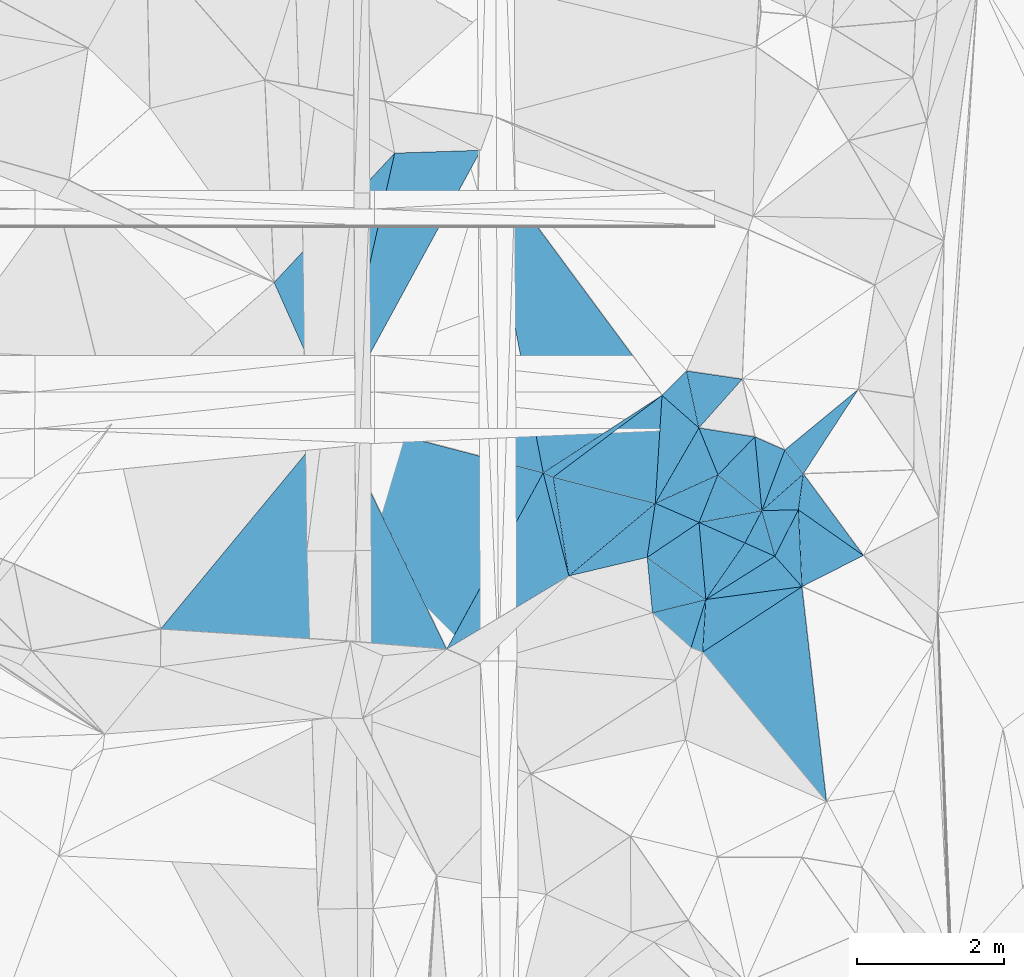
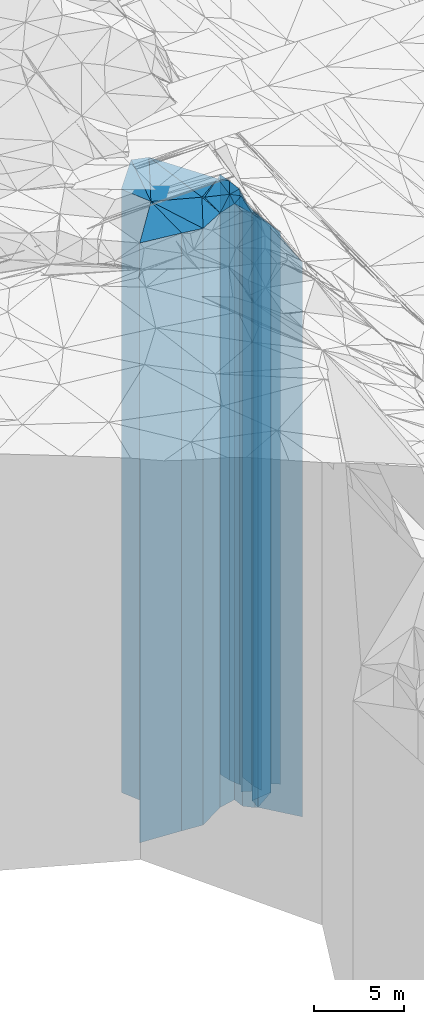
# One storey, part 210 of 275: 41 plates.
"""IFC2X3 building model written with IfcOpenShell, lengths in millimetres."""

from ifc_helpers import new_model, si_unit, frame, origin_with_axes, place, context, subcontext, project, spatial, faceted_brep, material, type_object, element, save


model = new_model("IFC2X3")

# Units and contexts
model_context = context("Model", 3, precision=1e-05, world=origin_with_axes())
body_context = subcontext(model_context, "Body", "Model", "MODEL_VIEW")
ifc_project = project(units=[si_unit("LENGTHUNIT", "METRE", prefix="MILLI"), si_unit("AREAUNIT", "SQUARE_METRE"), si_unit("VOLUMEUNIT", "CUBIC_METRE"), si_unit("MASSUNIT", "GRAM", prefix="KILO"), si_unit("TIMEUNIT", "SECOND"), si_unit("PLANEANGLEUNIT", "RADIAN"), si_unit("SOLIDANGLEUNIT", "STERADIAN"), si_unit("THERMODYNAMICTEMPERATUREUNIT", "DEGREE_CELSIUS"), si_unit("LUMINOUSINTENSITYUNIT", "LUMEN")], contexts=[model_context])

# Site, building, storey
site_placement = place(None, origin_with_axes())
site = spatial("IfcSite", under=ifc_project, at=site_placement, CompositionType="ELEMENT")
building_placement = place(site_placement, origin_with_axes())
building = spatial("IfcBuilding", under=site, at=building_placement, Name="Undefined", CompositionType="ELEMENT")
storey_placement = place(building_placement, origin_with_axes())
storey = spatial("IfcBuildingStorey", under=building, at=storey_placement, Name="Undefined", CompositionType="ELEMENT", Elevation=0.0)

# Plates
ifc_material = material()
plate_type_1 = type_object("IfcPlateType", PredefinedType="NOTDEFINED")
plate_1_placement = place(storey_placement, frame((-106841.743380967, 59287.7253005679, 28269.0), z_axis=(0.912580697493601, 0.408896650221169, 0.0), x_axis=(0.408896650221169, -0.912580697493601, 0.0)))
element("IfcPlate", 1, at=plate_1_placement, inside=storey, type_object=plate_type_1, material=ifc_material, Name="00", context=body_context, shape_type="Brep", body=[
    faceted_brep([(0.0, -20441.0, 0.0), (-939.052673339844, -20791.0, 2224.65283203125), (-939.052673339844, 20441.0, 2224.65283203125), (2.91038304567337e-11, 20441.0, -1.45519152283669e-11), (2030.02465820313, -20441.0, -2.77941580861807e-09), (2030.02465820313, 20441.0, -2.77941580861807e-09)], [[[0, 1, 2, 3]], [[1, 4, 5, 2]], [[4, 0, 3, 5]], [[5, 3, 2]], [[4, 1, 0]]]),
])
plate_type_2 = type_object("IfcPlateType", PredefinedType="NOTDEFINED")
plate_2_placement = place(storey_placement, frame((-105195.543648921, 61054.3397016786, 28269.0), z_axis=(0.975504880489168, -0.219977790110307, 0.0), x_axis=(-0.219977790110309, -0.975504880489168, 0.0)))
element("IfcPlate", 2, at=plate_2_placement, inside=storey, type_object=plate_type_2, material=ifc_material, Name="00", context=body_context, shape_type="Brep", body=[
    faceted_brep([(-2.91038304567337e-11, -20791.0, -8.86757334228605e-12), (-295.871704101563, -20531.0, 1137.6114501953), (-295.871704101563, 20441.0, 1137.6114501953), (2.91038304567337e-11, 20441.0, -1.45519152283669e-11), (3710.05395507813, -20441.0, -5.07861841470003e-09), (3710.05395507813, 20441.0, -5.07861841470003e-09)], [[[0, 1, 2, 3]], [[1, 4, 5, 2]], [[4, 0, 3, 5]], [[5, 3, 2]], [[4, 1, 0]]]),
])
plate_type_3 = type_object("IfcPlateType", PredefinedType="NOTDEFINED")
plate_3_placement = place(storey_placement, frame((-100452.641159948, 57968.796640872, 27609.0), z_axis=(-0.145895997045634, -0.989299933309439, 0.0), x_axis=(-0.989299933309439, 0.145895997045634, 0.0)))
element("IfcPlate", 3, at=plate_3_placement, inside=storey, type_object=plate_type_3, material=ifc_material, Name="00", context=body_context, shape_type="Brep", body=[
    faceted_brep([(1.45519152283669e-11, -19781.0, -7.27595761418343e-12), (487.70010375978, -20821.0, 745.082946777344), (487.70010375978, 19781.0, 745.082946777344), (0.0, 19781.0, 0.0), (768.505065917983, -20881.0, 2.48110154643655e-09), (768.505065917954, 19781.0, 2.48837750405073e-09)], [[[0, 1, 2, 3]], [[1, 4, 5, 2]], [[4, 0, 3, 5]], [[5, 3, 2]], [[4, 1, 0]]]),
])
plate_type_4 = type_object("IfcPlateType", PredefinedType="NOTDEFINED")
plate_4_placement = place(storey_placement, frame((-101638.750597907, 56274.4104979918, 28099.0), z_axis=(-0.865602585242508, 0.500731629140287, 0.0), x_axis=(0.500731629140283, 0.865602585242511, 0.0)))
element("IfcPlate", 4, at=plate_4_placement, inside=storey, type_object=plate_type_4, material=ifc_material, Name="00", context=body_context, shape_type="Brep", body=[
    faceted_brep([(-5.45696821063757e-12, -20271.0, 0.0), (1321.26062011717, -20411.0, 657.852783203125), (1321.26062011717, 20271.0, 657.852783203125), (-5.45696821063757e-12, 20271.0, 0.0), (1188.10778808592, -20331.0, -6.34463503956795e-09), (1188.10778808592, 20271.0, -6.34463503956795e-09)], [[[0, 1, 2, 3]], [[1, 4, 5, 2]], [[4, 0, 3, 5]], [[5, 3, 2]], [[4, 1, 0]]]),
])
plate_type_5 = type_object("IfcPlateType", PredefinedType="NOTDEFINED")
plate_5_placement = place(storey_placement, frame((-103168.085030163, 56691.5869526421, 28144.0), z_axis=(-0.545695816690895, 0.83798333852533, 0.0), x_axis=(0.83798333852533, 0.545695816690894, 0.0)))
element("IfcPlate", 5, at=plate_5_placement, inside=storey, type_object=plate_type_5, material=ifc_material, Name="00", context=body_context, shape_type="Brep", body=[
    faceted_brep([(-1.45519152283669e-11, -20316.0, 0.0), (1687.18908691407, -20656.0, 4153.34716796876), (1687.18908691407, 20316.0, 4153.34716796876), (0.0, 20316.0, 0.0), (1934.99353027344, -20366.0, 2.02271621674299e-09), (1934.99353027344, 20316.0, 2.02271621674299e-09)], [[[0, 1, 2, 3]], [[1, 4, 5, 2]], [[4, 0, 3, 5]], [[5, 3, 2]], [[4, 1, 0]]]),
])
plate_type_6 = type_object("IfcPlateType", PredefinedType="NOTDEFINED")
plate_6_placement = place(storey_placement, frame((-100183.947940648, 56174.1646580124, 27079.0), z_axis=(-0.935515923827576, 0.353284525934887, 0.0), x_axis=(0.353284525934885, 0.935515923827576, 0.0)))
element("IfcPlate", 6, at=plate_6_placement, inside=storey, type_object=plate_type_6, material=ifc_material, Name="00", context=body_context, shape_type="Brep", body=[
    faceted_brep([(0.0, -19491.0, 1.45519152283669e-11), (908.687988281257, -19921.0, 445.293304443374), (908.687988281257, 19251.0, 445.293304443374), (0.0, 19251.0, 1.45519152283669e-11), (883.911743164055, -19251.0, -1.33877620100975e-09), (883.911743164055, 19251.0, -1.33877620100975e-09)], [[[0, 1, 2, 3]], [[1, 4, 5, 2]], [[4, 0, 3, 5]], [[5, 3, 2]], [[4, 1, 0]]]),
])
plate_type_7 = type_object("IfcPlateType", PredefinedType="NOTDEFINED")
plate_7_placement = place(storey_placement, frame((-100183.947940648, 56174.1646580124, 26949.0), z_axis=(-0.663522728184493, 0.748156126208031, 0.0), x_axis=(0.748156126208028, 0.663522728184497, 0.0)))
element("IfcPlate", 7, at=plate_7_placement, inside=storey, type_object=plate_type_7, material=ifc_material, Name="00", context=body_context, shape_type="Brep", body=[
    faceted_brep([(0.0, -19621.0, 0.0), (782.304382324211, -19381.0, 411.460632324219), (782.304382324211, 19121.0, 411.460632324219), (0.0, 19121.0, 0.0), (755.843872070298, -19121.0, -3.60887497663498e-09), (755.843872070298, 19121.0, -3.60887497663498e-09)], [[[0, 1, 2, 3]], [[1, 4, 5, 2]], [[4, 0, 3, 5]], [[5, 3, 2]], [[4, 1, 0]]]),
])
plate_type_8 = type_object("IfcPlateType", PredefinedType="NOTDEFINED")
plate_8_placement = place(storey_placement, frame((-100183.947940648, 56174.1646580124, 26949.0), z_axis=(-0.0246161959885678, 0.999696975535613, 0.0), x_axis=(0.999696975535613, 0.0246161959885656, 0.0)))
element("IfcPlate", 8, at=plate_8_placement, inside=storey, type_object=plate_type_8, material=ifc_material, Name="00", context=body_context, shape_type="Brep", body=[
    faceted_brep([(0.0, -19621.0, 0.0), (577.663391113267, -19121.0, 487.447448730469), (577.663391113267, 19121.0, 487.447448730469), (0.0, 19121.0, 0.0), (497.694671630845, -19191.0, -1.30967237055302e-09), (497.694671630845, 19121.0, -1.30967237055302e-09)], [[[0, 1, 2, 3]], [[1, 4, 5, 2]], [[4, 0, 3, 5]], [[5, 3, 2]], [[4, 1, 0]]]),
])
plate_type_9 = type_object("IfcPlateType", PredefinedType="NOTDEFINED")
plate_9_placement = place(storey_placement, frame((-98869.9844511925, 57826.6778798589, 26484.0), z_axis=(0.636018240790832, -0.771674022746221, 0.0), x_axis=(-0.77167402274622, -0.636018240790834, 0.0)))
element("IfcPlate", 9, at=plate_9_placement, inside=storey, type_object=plate_type_9, material=ifc_material, Name="00", context=body_context, shape_type="Brep", body=[
    faceted_brep([(2.91038304567337e-11, -18656.0, 0.0), (1309.63110351564, -19586.0, 412.148590087876), (1309.63110351564, 18656.0, 412.148590087876), (0.0, 18656.0, 7.27595761418343e-12), (1298.07543945314, -19846.0, 5.0931703299284e-10), (1298.07543945314, 18656.0, 5.0931703299284e-10)], [[[0, 1, 2, 3]], [[1, 4, 5, 2]], [[4, 0, 3, 5]], [[5, 3, 2]], [[4, 1, 0]]]),
])
plate_type_10 = type_object("IfcPlateType", PredefinedType="NOTDEFINED")
plate_10_placement = place(storey_placement, frame((-101638.750597907, 56274.4104979918, 28009.0), z_axis=(-0.414102456121684, 0.910230276267489, 0.0), x_axis=(0.910230276267486, 0.414102456121689, 0.0)))
element("IfcPlate", 10, at=plate_10_placement, inside=storey, type_object=plate_type_10, material=ifc_material, Name="00", context=body_context, shape_type="Brep", body=[
    faceted_brep([(0.0, -20361.0, 1.45519152283669e-11), (967.39208984375, -20421.0, 689.748229980469), (967.39208984375, 20181.0, 689.748229980469), (2.91038304567337e-11, 20181.0, 0.0), (940.053161621108, -20181.0, 4.38012648373842e-09), (940.053161621108, 20181.0, 4.38012648373842e-09)], [[[0, 1, 2, 3]], [[1, 4, 5, 2]], [[4, 0, 3, 5]], [[5, 3, 2]], [[4, 1, 0]]]),
])
plate_type_11 = type_object("IfcPlateType", PredefinedType="NOTDEFINED")
plate_11_placement = place(storey_placement, frame((-101212.923146997, 58080.9184503828, 28129.0), z_axis=(0.706835456151179, -0.707378002151293, 0.0), x_axis=(-0.707378002151296, -0.706835456151176, 0.0)))
element("IfcPlate", 11, at=plate_11_placement, inside=storey, type_object=plate_type_11, material=ifc_material, Name="00", context=body_context, shape_type="Brep", body=[
    faceted_brep([(0.0, -20361.0, 1.45519152283669e-11), (430.359130859364, -20301.0, 669.918640136704), (430.359130859364, 20301.0, 669.918640136704), (-1.09139364212751e-11, 20301.0, -1.45519152283669e-11), (471.699066162098, -20381.0, 1.46974343806505e-09), (471.699066162098, 20301.0, 1.46974343806505e-09)], [[[0, 1, 2, 3]], [[1, 4, 5, 2]], [[4, 0, 3, 5]], [[5, 3, 2]], [[4, 1, 0]]]),
])
plate_type_12 = type_object("IfcPlateType", PredefinedType="NOTDEFINED")
plate_12_placement = place(storey_placement, frame((-101042.223484436, 56013.3446003834, 27199.0), z_axis=(-0.184170593919691, 0.982894293571424, 0.0), x_axis=(0.982894293571423, 0.184170593919695, 0.0)))
element("IfcPlate", 12, at=plate_12_placement, inside=storey, type_object=plate_type_12, material=ifc_material, Name="00", context=body_context, shape_type="Brep", body=[
    faceted_brep([(1.45519152283669e-11, -21011.0, 1.45519152283669e-11), (374.479309082031, -20991.0, 591.494079589858), (374.479309082031, 19371.0, 591.494079589858), (1.45519152283669e-11, 19371.0, 1.45519152283669e-11), (873.212463378921, -19371.0, 2.83762346953154e-09), (873.212463378921, 19371.0, 2.83762346953154e-09)], [[[0, 1, 2, 3]], [[1, 4, 5, 2]], [[4, 0, 3, 5]], [[5, 3, 2]], [[4, 1, 0]]]),
])
plate_type_13 = type_object("IfcPlateType", PredefinedType="NOTDEFINED")
plate_13_placement = place(storey_placement, frame((-100279.501523875, 57181.5719801679, 27414.0), z_axis=(-0.156699567990614, -0.987646315940861, 0.0), x_axis=(-0.987646315940861, 0.156699567990614, 0.0)))
element("IfcPlate", 13, at=plate_13_placement, inside=storey, type_object=plate_type_13, material=ifc_material, Name="00", context=body_context, shape_type="Brep", body=[
    faceted_brep([(1.45519152283669e-11, -19586.0, -1.45519152283669e-11), (416.210998535171, -20776.0, 590.396789550781), (416.210998535171, 19586.0, 590.396789550781), (-7.27595761418343e-12, 19586.0, 0.0), (773.886291503921, -21016.0, 1.16415321826935e-09), (773.886291503921, 19586.0, 1.16415321826935e-09)], [[[0, 1, 2, 3]], [[1, 4, 5, 2]], [[4, 0, 3, 5]], [[5, 3, 2]], [[4, 1, 0]]]),
])
plate_type_14 = type_object("IfcPlateType", PredefinedType="NOTDEFINED")
plate_14_placement = place(storey_placement, frame((-99637.6375923021, 55136.4532321864, 26529.0), z_axis=(-0.452404799933225, 0.891812702868365, 0.0), x_axis=(0.891812702868366, 0.452404799933223, 0.0)))
element("IfcPlate", 14, at=plate_14_placement, inside=storey, type_object=plate_type_14, material=ifc_material, Name="00", context=body_context, shape_type="Brep", body=[
    faceted_brep([(-1.45519152283669e-11, -19731.0, 0.0), (431.517639160164, -19611.0, 958.432312011719), (431.517639160164, 18701.0, 958.432312011719), (-1.45519152283669e-11, 18701.0, 0.0), (941.328857421853, -18701.0, 1.12049747258425e-09), (941.328857421853, 18701.0, 1.12049747258425e-09)], [[[0, 1, 2, 3]], [[1, 4, 5, 2]], [[4, 0, 3, 5]], [[5, 3, 2]], [[4, 1, 0]]]),
])
plate_type_15 = type_object("IfcPlateType", PredefinedType="NOTDEFINED")
plate_15_placement = place(storey_placement, frame((-99618.4586970826, 56675.6842642209, 26529.0), z_axis=(0.990494632365923, -0.137551384050815, 0.0), x_axis=(-0.137551384050824, -0.990494632365922, 0.0)))
element("IfcPlate", 15, at=plate_15_placement, inside=storey, type_object=plate_type_15, material=ifc_material, Name="00", context=body_context, shape_type="Brep", body=[
    faceted_brep([(-7.27595761418343e-12, -19541.0, 0.0), (989.951538085945, -18701.0, 965.658264160156), (989.951538085945, 18701.0, 965.658264160156), (-1.45519152283669e-11, 18701.0, 0.0), (493.963562011719, -19611.0, -5.23868948221207e-10), (493.963562011719, 18701.0, -5.23868948221207e-10)], [[[0, 1, 2, 3]], [[1, 4, 5, 2]], [[4, 0, 3, 5]], [[5, 3, 2]], [[4, 1, 0]]]),
])
plate_type_16 = type_object("IfcPlateType", PredefinedType="NOTDEFINED")
plate_16_placement = place(storey_placement, frame((-101042.223484436, 56013.3446003834, 27199.0), z_axis=(0.40829029704525, 0.912852142101174, 0.0), x_axis=(0.912852142101172, -0.408290297045255, 0.0)))
element("IfcPlate", 16, at=plate_16_placement, inside=storey, type_object=plate_type_16, material=ifc_material, Name="00", context=body_context, shape_type="Brep", body=[
    faceted_brep([(1.45519152283669e-11, -21011.0, 1.45519152283669e-11), (717.817382812485, -19371.0, 497.230499267573), (717.817382812485, 19371.0, 497.230499267573), (1.45519152283669e-11, 19371.0, 1.45519152283669e-11), (686.804199218735, -19911.0, -2.42107489611954e-09), (686.804199218735, 19371.0, -2.42107489611954e-09)], [[[0, 1, 2, 3]], [[1, 4, 5, 2]], [[4, 0, 3, 5]], [[5, 3, 2]], [[4, 1, 0]]]),
])
plate_type_17 = type_object("IfcPlateType", PredefinedType="NOTDEFINED")
plate_17_placement = place(storey_placement, frame((-100183.947940648, 56174.1646580124, 27144.0), z_axis=(0.885665246512403, -0.464324316744369, 0.0), x_axis=(-0.464324316744365, -0.885665246512405, 0.0)))
element("IfcPlate", 17, at=plate_17_placement, inside=storey, type_object=plate_type_17, material=ifc_material, Name="00", context=body_context, shape_type="Brep", body=[
    faceted_brep([(7.27595761418343e-12, -19426.0, 0.0), (468.690338134773, -19316.0, 445.004913330078), (468.690338134773, 19316.0, 445.004913330078), (7.27595761418343e-12, 19316.0, 0.0), (498.196746826172, -19966.0, -1.33877620100975e-09), (498.196746826172, 19316.0, -1.33877620100975e-09)], [[[0, 1, 2, 3]], [[1, 4, 5, 2]], [[4, 0, 3, 5]], [[5, 3, 2]], [[4, 1, 0]]]),
])
plate_type_18 = type_object("IfcPlateType", PredefinedType="NOTDEFINED")
plate_18_placement = place(storey_placement, frame((-101749.814494169, 55536.464151062, 28019.0), z_axis=(-0.558874123941729, 0.829252502913537, 0.0), x_axis=(0.829252502913538, 0.558874123941726, 0.0)))
element("IfcPlate", 18, at=plate_18_placement, inside=storey, type_object=plate_type_18, material=ifc_material, Name="00", context=body_context, shape_type="Brep", body=[
    faceted_brep([(-7.27595761418343e-12, -20201.0, 0.0), (504.519134521477, -20351.0, 549.873107910171), (504.519134521477, 20191.0, 549.873107910171), (0.0, 20191.0, 0.0), (853.287780761711, -20191.0, 8.87666828930378e-10), (853.287780761711, 20191.0, 8.87666828930378e-10)], [[[0, 1, 2, 3]], [[1, 4, 5, 2]], [[4, 0, 3, 5]], [[5, 3, 2]], [[4, 1, 0]]]),
])
plate_type_19 = type_object("IfcPlateType", PredefinedType="NOTDEFINED")
plate_19_placement = place(storey_placement, frame((-101546.592683376, 57747.5048326457, 28099.0), z_axis=(0.600661016016313, -0.799503811021718, 0.0), x_axis=(-0.799503811021718, -0.600661016016313, 0.0)))
element("IfcPlate", 19, at=plate_19_placement, inside=storey, type_object=plate_type_19, material=ifc_material, Name="00", context=body_context, shape_type="Brep", body=[
    faceted_brep([(7.27595761418343e-12, -20411.0, 2.91038304567337e-11), (958.510925292961, -20271.0, 1122.38891601564), (958.510925292961, 20271.0, 1122.38891601564), (-5.45696821063757e-12, 20271.0, 0.0), (1858.09045410158, -20351.0, 3.88536136597395e-09), (1858.09045410158, 20271.0, 3.88536136597395e-09)], [[[0, 1, 2, 3]], [[1, 4, 5, 2]], [[4, 0, 3, 5]], [[5, 3, 2]], [[4, 1, 0]]]),
])
plate_type_20 = type_object("IfcPlateType", PredefinedType="NOTDEFINED")
plate_20_placement = place(storey_placement, frame((-100948.785727706, 54961.2659979884, 27469.0), z_axis=(-0.822548909060159, 0.568694375041588, 0.0), x_axis=(0.568694375041594, 0.822548909060155, 0.0)))
element("IfcPlate", 20, at=plate_20_placement, inside=storey, type_object=plate_type_20, material=ifc_material, Name="00", context=body_context, shape_type="Brep", body=[
    faceted_brep([(0.0, -20141.0, -7.27595761418343e-12), (812.248596191419, -20741.0, 675.168334960938), (812.248596191419, 19641.0, 675.168334960938), (5.45696821063757e-12, 19641.0, 0.0), (938.136474609373, -19641.0, -8.14907252788544e-10), (938.136474609373, 19641.0, -8.14907252788544e-10)], [[[0, 1, 2, 3]], [[1, 4, 5, 2]], [[4, 0, 3, 5]], [[5, 3, 2]], [[4, 1, 0]]]),
])
plate_type_21 = type_object("IfcPlateType", PredefinedType="NOTDEFINED")
plate_21_placement = place(storey_placement, frame((-100783.085723055, 56663.6888327913, 28009.0), z_axis=(0.414102456121684, -0.910230276267489, 0.0), x_axis=(-0.910230276267486, -0.414102456121691, 0.0)))
element("IfcPlate", 21, at=plate_21_placement, inside=storey, type_object=plate_type_21, material=ifc_material, Name="00", context=body_context, shape_type="Brep", body=[
    faceted_brep([(2.91038304567337e-11, -20181.0, 0.0), (505.184173583999, -20201.0, 484.65341186522), (505.184173583999, 20181.0, 484.65341186522), (2.91038304567337e-11, 20181.0, 0.0), (940.053161621108, -20361.0, 4.35102265328169e-09), (940.053161621108, 20181.0, 4.38012648373842e-09)], [[[0, 1, 2, 3]], [[1, 4, 5, 2]], [[4, 0, 3, 5]], [[5, 3, 2]], [[4, 1, 0]]]),
])
plate_type_22 = type_object("IfcPlateType", PredefinedType="NOTDEFINED")
plate_22_placement = place(storey_placement, frame((-100948.785727706, 54961.2659979884, 27144.0), z_axis=(-0.531830128137156, 0.846851058218396, 0.0), x_axis=(0.846851058218398, 0.531830128137152, 0.0)))
element("IfcPlate", 22, at=plate_22_placement, inside=storey, type_object=plate_type_22, material=ifc_material, Name="00", context=body_context, shape_type="Brep", body=[
    faceted_brep([(2.18278728425503e-11, -20466.0, 0.0), (862.199645996101, -19966.0, 369.745483398452), (862.199645996101, 19316.0, 369.745483398452), (7.27595761418343e-12, 19316.0, 0.0), (1111.57543945311, -19316.0, -5.42786438018084e-09), (1111.57543945311, 19316.0, -5.42786438018084e-09)], [[[0, 1, 2, 3]], [[1, 4, 5, 2]], [[4, 0, 3, 5]], [[5, 3, 2]], [[4, 1, 0]]]),
])
plate_type_23 = type_object("IfcPlateType", PredefinedType="NOTDEFINED")
plate_23_placement = place(storey_placement, frame((-100279.501523875, 57181.5719801679, 27199.0), z_axis=(0.716934931852036, -0.697140088856118, 0.0), x_axis=(-0.697140088856117, -0.716934931852037, 0.0)))
element("IfcPlate", 23, at=plate_23_placement, inside=storey, type_object=plate_type_23, material=ifc_material, Name="00", context=body_context, shape_type="Brep", body=[
    faceted_brep([(2.91038304567337e-11, -19801.0, 0.0), (655.631286621101, -19371.0, 770.809753417954), (655.631286621101, 19371.0, 770.809753417954), (1.45519152283669e-11, 19371.0, 1.45519152283669e-11), (722.357238769539, -20991.0, 1.57160684466362e-09), (722.357238769539, 19371.0, 1.57160684466362e-09)], [[[0, 1, 2, 3]], [[1, 4, 5, 2]], [[4, 0, 3, 5]], [[5, 3, 2]], [[4, 1, 0]]]),
])
plate_type_24 = type_object("IfcPlateType", PredefinedType="NOTDEFINED")
plate_24_placement = place(storey_placement, frame((-100948.785727706, 54961.2659979884, 27044.0), z_axis=(-0.132436669032172, 0.991191469240763, 0.0), x_axis=(0.991191469240764, 0.132436669032169, 0.0)))
element("IfcPlate", 24, at=plate_24_placement, inside=storey, type_object=plate_type_24, material=ifc_material, Name="00", context=body_context, shape_type="Brep", body=[
    faceted_brep([(1.45519152283669e-11, -20566.0, 0.0), (1011.33953857422, -19416.0, 461.29418945314), (1011.33953857422, 19216.0, 461.29418945314), (0.0, 19216.0, 0.0), (1322.80004882813, -19216.0, -2.61934474110603e-09), (1322.80004882813, 19216.0, -2.61934474110603e-09)], [[[0, 1, 2, 3]], [[1, 4, 5, 2]], [[4, 0, 3, 5]], [[5, 3, 2]], [[4, 1, 0]]]),
])
plate_type_25 = type_object("IfcPlateType", PredefinedType="NOTDEFINED")
plate_25_placement = place(storey_placement, frame((-99686.4040687923, 56186.416008084, 26984.0), z_axis=(0.892134515534765, -0.451769859764406, 0.0), x_axis=(-0.451769859764408, -0.892134515534764, 0.0)))
element("IfcPlate", 25, at=plate_25_placement, inside=storey, type_object=plate_type_25, material=ifc_material, Name="00", context=body_context, shape_type="Brep", body=[
    faceted_brep([(0.0, -19156.0, -1.45519152283669e-11), (914.676818847656, -19276.0, 517.847778320298), (914.676818847656, 19156.0, 517.847778320298), (0.0, 19156.0, -1.45519152283669e-11), (710.633544921875, -19476.0, 1.68802216649055e-09), (710.633544921875, 19156.0, 1.68802216649055e-09)], [[[0, 1, 2, 3]], [[1, 4, 5, 2]], [[4, 0, 3, 5]], [[5, 3, 2]], [[4, 1, 0]]]),
])
plate_type_26 = type_object("IfcPlateType", PredefinedType="NOTDEFINED")
plate_26_placement = place(storey_placement, frame((-99686.4040687923, 56186.416008084, 26984.0), z_axis=(0.0246161959885678, -0.999696975535613, 0.0), x_axis=(-0.999696975535613, -0.0246161959885656, 0.0)))
element("IfcPlate", 26, at=plate_26_placement, inside=storey, type_object=plate_type_26, material=ifc_material, Name="00", context=body_context, shape_type="Brep", body=[
    faceted_brep([(0.0, -19156.0, -1.45519152283669e-11), (336.551727294922, -19476.0, 625.885742187493), (336.551727294922, 19156.0, 625.885742187493), (0.0, 19156.0, -1.45519152283669e-11), (497.694671630874, -19586.0, -1.32422428578138e-09), (497.694671630874, 19156.0, -1.32422428578138e-09)], [[[0, 1, 2, 3]], [[1, 4, 5, 2]], [[4, 0, 3, 5]], [[5, 3, 2]], [[4, 1, 0]]]),
])
plate_type_27 = type_object("IfcPlateType", PredefinedType="NOTDEFINED")
plate_27_placement = place(storey_placement, frame((-104020.712871003, 61092.7147359524, 28144.0), z_axis=(0.878305851195556, -0.47809918610645, 0.0), x_axis=(-0.478099186106448, -0.878305851195557, 0.0)))
element("IfcPlate", 27, at=plate_27_placement, inside=storey, type_object=plate_type_27, material=ifc_material, Name="00", context=body_context, shape_type="Brep", body=[
    faceted_brep([(0.0, -20656.0, 1.45519152283669e-11), (3457.89550781249, -20316.0, 2853.04370117186), (3457.89550781249, 20316.0, 2853.04370117186), (0.0, 20316.0, 0.0), (4164.32470703124, -20566.0, -3.04135028272867e-09), (4164.32470703124, 20316.0, -3.04135028272867e-09)], [[[0, 1, 2, 3]], [[1, 4, 5, 2]], [[4, 0, 3, 5]], [[5, 3, 2]], [[4, 1, 0]]]),
])
plate_type_28 = type_object("IfcPlateType", PredefinedType="NOTDEFINED")
plate_28_placement = place(storey_placement, frame((-101638.750597907, 56274.4104979918, 27974.0), z_axis=(-0.248200352131922, -0.968708720514887, 0.0), x_axis=(-0.968708720514887, 0.248200352131924, 0.0)))
element("IfcPlate", 28, at=plate_28_placement, inside=storey, type_object=plate_type_28, material=ifc_material, Name="00", context=body_context, shape_type="Brep", body=[
    faceted_brep([(2.91038304567337e-11, -20396.0, 1.09139364212751e-11), (896.620056152373, -20146.0, 1253.54394531251), (896.620056152373, 20146.0, 1253.54394531251), (2.91038304567337e-11, 20146.0, 1.09139364212751e-11), (1438.40185546878, -20476.0, 1.13504938781261e-09), (1438.40185546878, 20146.0, 1.13504938781261e-09)], [[[0, 1, 2, 3]], [[1, 4, 5, 2]], [[4, 0, 3, 5]], [[5, 3, 2]], [[4, 1, 0]]]),
])
plate_type_29 = type_object("IfcPlateType", PredefinedType="NOTDEFINED")
plate_29_placement = place(storey_placement, frame((-103032.143053218, 56631.4223542131, 27974.0), z_axis=(-0.404710884868236, -0.914444694702293, 0.0), x_axis=(-0.914444694702307, 0.404710884868205, 0.0)))
element("IfcPlate", 29, at=plate_29_placement, inside=storey, type_object=plate_type_29, material=ifc_material, Name="00", context=body_context, shape_type="Brep", body=[
    faceted_brep([(0.0, -20476.0, -1.45519152283669e-11), (-741.285400390669, -20146.0, 1146.90710449218), (-741.285400390669, 20146.0, 1146.90710449218), (2.91038304567337e-11, 20146.0, 1.09139364212751e-11), (148.660690307617, -20486.0, -8.71295924298465e-10), (148.660690307617, 20146.0, -8.71295924298465e-10)], [[[0, 1, 2, 3]], [[1, 4, 5, 2]], [[4, 0, 3, 5]], [[5, 3, 2]], [[4, 1, 0]]]),
])
plate_type_30 = type_object("IfcPlateType", PredefinedType="NOTDEFINED")
plate_30_placement = place(storey_placement, frame((-101546.592683376, 57747.5048326457, 28139.0), z_axis=(0.545695816690895, -0.83798333852533, 0.0), x_axis=(-0.83798333852533, -0.545695816690894, 0.0)))
element("IfcPlate", 30, at=plate_30_placement, inside=storey, type_object=plate_type_30, material=ifc_material, Name="00", context=body_context, shape_type="Brep", body=[
    faceted_brep([(0.0, -20371.0, 0.0), (1853.90795898436, -20311.0, 124.599899291992), (1853.90795898436, 20311.0, 124.599899291992), (2.91038304567337e-11, 20311.0, 3.63797880709171e-12), (1934.99353027344, -20321.0, 2.00816430151463e-09), (1934.99353027344, 20311.0, 2.00816430151463e-09)], [[[0, 1, 2, 3]], [[1, 4, 5, 2]], [[4, 0, 3, 5]], [[5, 3, 2]], [[4, 1, 0]]]),
])
plate_type_31 = type_object("IfcPlateType", PredefinedType="NOTDEFINED")
plate_31_placement = place(storey_placement, frame((-103168.085030163, 56691.5869526421, 28044.0), z_axis=(-0.252986155924264, -0.967469898710376, 0.0), x_axis=(-0.967469898710375, 0.252986155924265, 0.0)))
element("IfcPlate", 31, at=plate_31_placement, inside=storey, type_object=plate_type_31, material=ifc_material, Name="00", context=body_context, shape_type="Brep", body=[
    faceted_brep([(0.0, -20416.0, 1.45519152283669e-11), (666.133483886733, -20216.0, 2664.12573242186), (666.133483886733, 20216.0, 2664.12573242186), (0.0, 20216.0, 0.0), (2939.20068359375, -20666.0, -4.90035745315254e-09), (2939.20068359375, 20216.0, -4.90035745315254e-09)], [[[0, 1, 2, 3]], [[1, 4, 5, 2]], [[4, 0, 3, 5]], [[5, 3, 2]], [[4, 1, 0]]]),
])
plate_type_32 = type_object("IfcPlateType", PredefinedType="NOTDEFINED")
plate_32_placement = place(storey_placement, frame((-101678.149306749, 54780.9086594453, 27719.0), z_axis=(-0.240050074002603, 0.970760507010532, 0.0), x_axis=(0.970760507010532, 0.240050074002603, 0.0)))
element("IfcPlate", 32, at=plate_32_placement, inside=storey, type_object=plate_type_32, material=ifc_material, Name="00", context=body_context, shape_type="Brep", body=[
    faceted_brep([(7.27595761418343e-12, -20411.0, 2.91038304567337e-11), (111.801414489746, -20501.0, 750.666687011719), (111.801414489746, 19891.0, 750.666687011719), (-1.45519152283669e-11, 19891.0, 0.0), (751.332153320298, -19891.0, -9.45874489843845e-10), (751.332153320298, 19891.0, -9.45874489843845e-10)], [[[0, 1, 2, 3]], [[1, 4, 5, 2]], [[4, 0, 3, 5]], [[5, 3, 2]], [[4, 1, 0]]]),
])
plate_type_33 = type_object("IfcPlateType", PredefinedType="NOTDEFINED")
plate_33_placement = place(storey_placement, frame((-102818.444328002, 55282.6329507697, 27974.0), z_axis=(-0.231099677077141, 0.972930079324738, 0.0), x_axis=(0.97293007932474, 0.231099677077134, 0.0)))
element("IfcPlate", 33, at=plate_33_placement, inside=storey, type_object=plate_type_33, material=ifc_material, Name="00", context=body_context, shape_type="Brep", body=[
    faceted_brep([(-1.45519152283669e-11, -20146.0, 0.0), (1376.958984375, -20396.0, 692.303344726577), (1376.958984375, 20146.0, 692.303344726577), (2.91038304567337e-11, 20146.0, 1.09139364212751e-11), (1098.3624267578, -20246.0, 3.66708263754845e-09), (1098.3624267578, 20146.0, 3.66708263754845e-09)], [[[0, 1, 2, 3]], [[1, 4, 5, 2]], [[4, 0, 3, 5]], [[5, 3, 2]], [[4, 1, 0]]]),
])
plate_type_34 = type_object("IfcPlateType", PredefinedType="NOTDEFINED")
plate_34_placement = place(storey_placement, frame((-99637.6375923021, 55136.4532321864, 27044.0), z_axis=(0.132436669032172, -0.991191469240763, 0.0), x_axis=(-0.991191469240764, -0.132436669032169, 0.0)))
element("IfcPlate", 34, at=plate_34_placement, inside=storey, type_object=plate_type_34, material=ifc_material, Name="00", context=body_context, shape_type="Brep", body=[
    faceted_brep([(1.45519152283669e-11, -19216.0, -1.45519152283669e-11), (1460.61376953125, -20956.0, 706.758361816392), (1460.61376953125, 19216.0, 706.758361816392), (0.0, 19216.0, 0.0), (1322.80004882814, -20566.0, -2.64844857156277e-09), (1322.80004882813, 19216.0, -2.61934474110603e-09)], [[[0, 1, 2, 3]], [[1, 4, 5, 2]], [[4, 0, 3, 5]], [[5, 3, 2]], [[4, 1, 0]]]),
])
plate_type_35 = type_object("IfcPlateType", PredefinedType="NOTDEFINED")
plate_35_placement = place(storey_placement, frame((-101042.223484436, 56013.3446003834, 27719.0), z_axis=(0.558874123941731, -0.829252502913535, 0.0), x_axis=(-0.829252502913538, -0.558874123941726, 0.0)))
element("IfcPlate", 35, at=plate_35_placement, inside=storey, type_object=plate_type_35, material=ifc_material, Name="00", context=body_context, shape_type="Brep", body=[
    faceted_brep([(-2.91038304567337e-11, -20491.0, 0.0), (510.496002197258, -19891.0, 924.658752441421), (510.496002197258, 19891.0, 924.658752441421), (-1.45519152283669e-11, 19891.0, 0.0), (853.287780761726, -20501.0, 8.58562998473644e-10), (853.287780761726, 19891.0, 8.58562998473644e-10)], [[[0, 1, 2, 3]], [[1, 4, 5, 2]], [[4, 0, 3, 5]], [[5, 3, 2]], [[4, 1, 0]]]),
])
plate_type_36 = type_object("IfcPlateType", PredefinedType="NOTDEFINED")
plate_36_placement = place(storey_placement, frame((-104486.536091256, 54282.6480162005, 27974.0), z_axis=(-0.514166750066084, 0.857690243110227, 0.0), x_axis=(0.857690243110228, 0.514166750066082, 0.0)))
element("IfcPlate", 36, at=plate_36_placement, inside=storey, type_object=plate_type_36, material=ifc_material, Name="00", context=body_context, shape_type="Brep", body=[
    faceted_brep([(-1.09139364212751e-11, -20286.0, -1.45519152283669e-11), (2369.41894531249, -20486.0, 1388.21972656251), (2369.41894531249, 20146.0, 1388.21972656251), (2.91038304567337e-11, 20146.0, 1.09139364212751e-11), (1944.86499023437, -20146.0, 1.10157998278737e-08), (1944.86499023437, 20146.0, 1.10157998278737e-08)], [[[0, 1, 2, 3]], [[1, 4, 5, 2]], [[4, 0, 3, 5]], [[5, 3, 2]], [[4, 1, 0]]]),
])
plate_type_37 = type_object("IfcPlateType", PredefinedType="NOTDEFINED")
plate_37_placement = place(storey_placement, frame((-99637.6375923021, 55136.4532321864, 26614.0), z_axis=(0.550942885111311, -0.834542951168617, 0.0), x_axis=(-0.834542951168613, -0.550942885111317, 0.0)))
element("IfcPlate", 37, at=plate_37_placement, inside=storey, type_object=plate_type_37, material=ifc_material, Name="00", context=body_context, shape_type="Brep", body=[
    faceted_brep([(7.27595761418343e-12, -19646.0, 1.45519152283669e-11), (1336.97241210938, -18786.0, 2634.25610351564), (1336.97241210938, 18786.0, 2634.25610351564), (0.0, 18786.0, -1.81898940354586e-12), (1622.62133789064, -21386.0, -4.35102265328169e-09), (1622.62133789064, 18786.0, -4.35102265328169e-09)], [[[0, 1, 2, 3]], [[1, 4, 5, 2]], [[4, 0, 3, 5]], [[5, 3, 2]], [[4, 1, 0]]]),
])
plate_type_38 = type_object("IfcPlateType", PredefinedType="NOTDEFINED")
plate_38_placement = place(storey_placement, frame((-100948.785727706, 54961.2659979884, 27719.0), z_axis=(0.240050074002603, -0.970760507010532, 0.0), x_axis=(-0.970760507010531, -0.240050074002607, 0.0)))
element("IfcPlate", 38, at=plate_38_placement, inside=storey, type_object=plate_type_38, material=ifc_material, Name="00", context=body_context, shape_type="Brep", body=[
    faceted_brep([(0.0, -19891.0, 0.0), (353.239257812515, -20341.0, 590.018676757813), (353.239257812515, 19891.0, 590.018676757813), (-1.45519152283669e-11, 19891.0, 0.0), (751.332153320313, -20411.0, -9.45874489843845e-10), (751.332153320298, 19891.0, -9.45874489843845e-10)], [[[0, 1, 2, 3]], [[1, 4, 5, 2]], [[4, 0, 3, 5]], [[5, 3, 2]], [[4, 1, 0]]]),
])
plate_type_39 = type_object("IfcPlateType", PredefinedType="NOTDEFINED")
plate_39_placement = place(storey_placement, frame((-106011.673109198, 57435.1640076748, 28044.0), z_axis=(0.997643339113793, 0.0686131760078249, 0.0), x_axis=(0.0686131760078269, -0.997643339113793, 0.0)))
element("IfcPlate", 39, at=plate_39_placement, inside=storey, type_object=plate_type_39, material=ifc_material, Name="00", context=body_context, shape_type="Brep", body=[
    faceted_brep([(0.0, -20666.0, -1.45519152283669e-11), (3249.73095703124, -20216.0, 1305.23864746094), (3249.73095703124, 20216.0, 1305.23864746094), (0.0, 20216.0, 0.0), (3052.62182617188, -20296.0, -6.92671164870262e-09), (3052.62182617188, 20216.0, -6.92671164870262e-09)], [[[0, 1, 2, 3]], [[1, 4, 5, 2]], [[4, 0, 3, 5]], [[5, 3, 2]], [[4, 1, 0]]]),
])
plate_type_40 = type_object("IfcPlateType", PredefinedType="NOTDEFINED")
plate_40_placement = place(storey_placement, frame((-101150.062407426, 54303.70406311, 27719.0), z_axis=(0.360757109901238, 0.932659802744659, 0.0), x_axis=(0.932659802744688, -0.360757109901163, 0.0)))
element("IfcPlate", 40, at=plate_40_placement, inside=storey, type_object=plate_type_40, material=ifc_material, Name="00", context=body_context, shape_type="Brep", body=[
    faceted_brep([(7.27595761418343e-12, -20341.0, 1.45519152283669e-11), (-49.4974746704102, -19891.0, 685.893554687498), (-49.4974746704102, 19891.0, 685.893554687498), (-1.45519152283669e-11, 19891.0, 0.0), (169.705627441421, -20281.0, 6.82121026329696e-10), (169.705627441421, 19891.0, 6.82121026329696e-10)], [[[0, 1, 2, 3]], [[1, 4, 5, 2]], [[4, 0, 3, 5]], [[5, 3, 2]], [[4, 1, 0]]]),
])
plate_type_41 = type_object("IfcPlateType", PredefinedType="NOTDEFINED")
plate_41_placement = place(storey_placement, frame((-108391.041459215, 54557.1253951925, 28084.0), z_axis=(0.0645238010241575, 0.997916168373574, 0.0), x_axis=(0.997916168373574, -0.0645238010241551, 0.0)))
element("IfcPlate", 41, at=plate_41_placement, inside=storey, type_object=plate_type_41, material=ifc_material, Name="00", context=body_context, shape_type="Brep", body=[
    faceted_brep([(-1.45519152283669e-11, -20386.0, 7.27595761418343e-12), (2188.70825195311, -20626.0, 3025.56713867188), (2188.70825195311, 20256.0, 3025.56713867188), (-1.45519152283669e-11, 20256.0, 7.27595761418343e-12), (2594.22436523436, -20256.0, 3.48518369719386e-09), (2594.22436523436, 20256.0, 3.48518369719386e-09)], [[[0, 1, 2, 3]], [[1, 4, 5, 2]], [[4, 0, 3, 5]], [[5, 3, 2]], [[4, 1, 0]]]),
])

save(model, "model.ifc")
